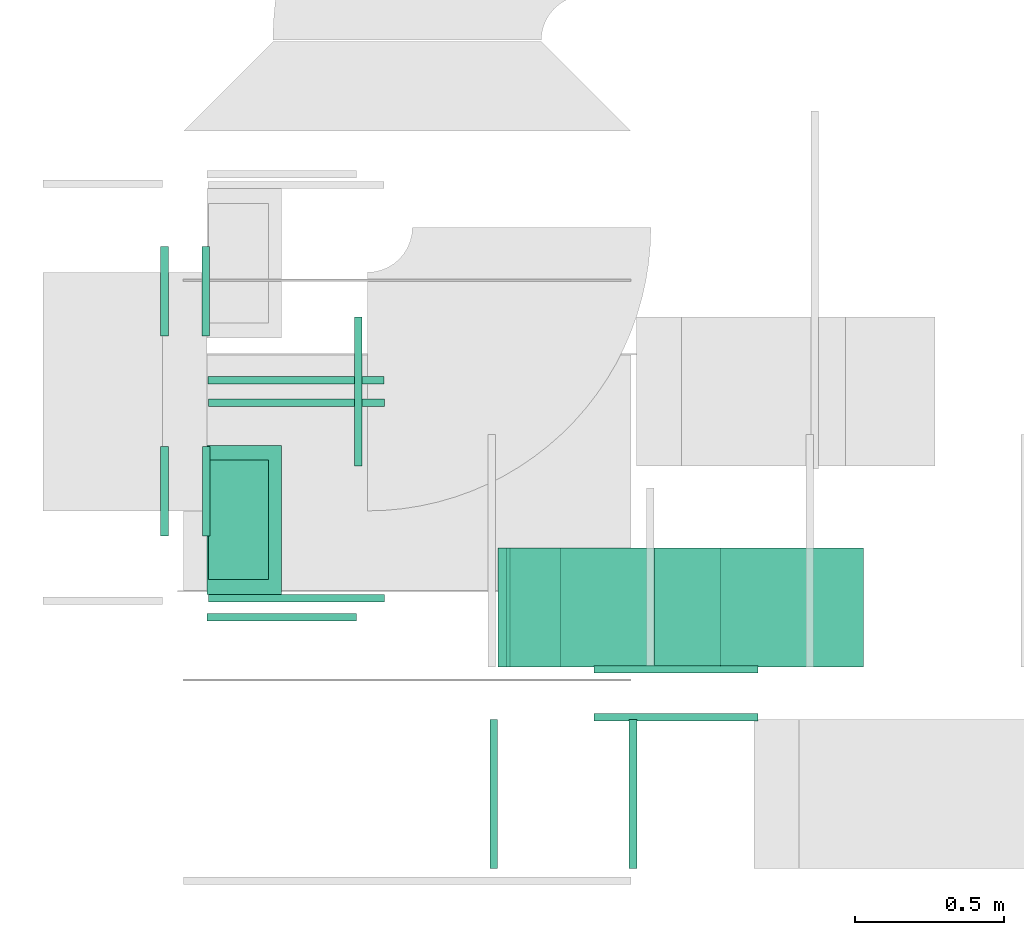
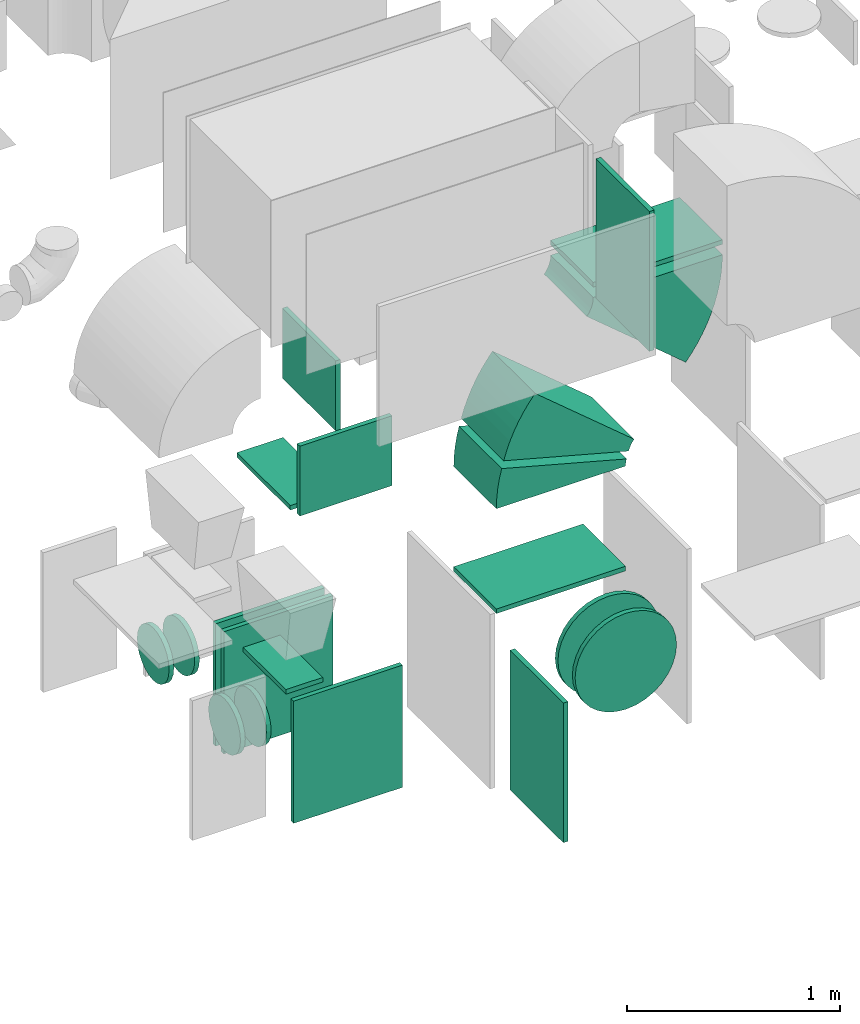
# One storey, part 13 of 59: 20 flow fittings.
"""IFC2X3 building model written with IfcOpenShell, lengths in millimetres."""

from ifc_helpers import new_model, entity, si_unit, converted_unit, derived_unit, direction, frame, frame_2d, origin, origin_2d_with_axis, place, context, subcontext, project, spatial, polyline, circle_curve, parameter, trimmed, segment, composite_curve, rectangle, outline, extrude, faceted_brep, source, transform, mapped, material, type_object, type_shapes, element, save


model = new_model("IFC2X3")

# Units and contexts
model_context = context("Model", 3, precision=0.01, world=origin(), true_north=direction((6.12303176911189e-17, 1.0)))
body_context = subcontext(model_context, "Body", "Model", "MODEL_VIEW")
ifc_project = project(units=[si_unit("LENGTHUNIT", "METRE", prefix="MILLI"), si_unit("AREAUNIT", "SQUARE_METRE"), si_unit("VOLUMEUNIT", "CUBIC_METRE"), converted_unit("PLANEANGLEUNIT", "DEGREE", entity("IfcRatioMeasure", 0.0174532925199433), si_unit("PLANEANGLEUNIT", "RADIAN"), dimensions=[0, 0, 0, 0, 0, 0, 0]), si_unit("MASSUNIT", "GRAM", prefix="KILO"), derived_unit("MASSDENSITYUNIT", [(si_unit("MASSUNIT", "GRAM", prefix="KILO"), 1), (si_unit("LENGTHUNIT", "METRE"), -3)]), derived_unit("MOMENTOFINERTIAUNIT", [(si_unit("LENGTHUNIT", "METRE"), 4)]), si_unit("TIMEUNIT", "SECOND"), si_unit("FREQUENCYUNIT", "HERTZ"), si_unit("THERMODYNAMICTEMPERATUREUNIT", "DEGREE_CELSIUS"), derived_unit("THERMALTRANSMITTANCEUNIT", [(si_unit("MASSUNIT", "GRAM", prefix="KILO"), 1), (si_unit("THERMODYNAMICTEMPERATUREUNIT", "KELVIN"), -1), (si_unit("TIMEUNIT", "SECOND"), -3)]), derived_unit("VOLUMETRICFLOWRATEUNIT", [(si_unit("LENGTHUNIT", "METRE"), 3), (si_unit("TIMEUNIT", "SECOND"), -1)]), derived_unit("MASSFLOWRATEUNIT", [(si_unit("MASSUNIT", "GRAM", prefix="KILO"), 1), (si_unit("TIMEUNIT", "SECOND"), -1)]), derived_unit("ROTATIONALFREQUENCYUNIT", [(si_unit("TIMEUNIT", "SECOND"), -1)]), si_unit("ELECTRICCURRENTUNIT", "AMPERE"), si_unit("ELECTRICVOLTAGEUNIT", "VOLT"), si_unit("POWERUNIT", "WATT"), si_unit("FORCEUNIT", "NEWTON", prefix="KILO"), si_unit("ILLUMINANCEUNIT", "LUX"), si_unit("LUMINOUSFLUXUNIT", "LUMEN"), si_unit("LUMINOUSINTENSITYUNIT", "CANDELA"), derived_unit("USERDEFINED", [(si_unit("MASSUNIT", "GRAM", prefix="KILO"), -1), (si_unit("LENGTHUNIT", "METRE"), -2), (si_unit("TIMEUNIT", "SECOND"), 3), (si_unit("LUMINOUSFLUXUNIT", "LUMEN"), 1)]), derived_unit("LINEARVELOCITYUNIT", [(si_unit("LENGTHUNIT", "METRE"), 1), (si_unit("TIMEUNIT", "SECOND"), -1)]), si_unit("PRESSUREUNIT", "PASCAL"), derived_unit("USERDEFINED", [(si_unit("LENGTHUNIT", "METRE"), -2), (si_unit("MASSUNIT", "GRAM", prefix="KILO"), 1), (si_unit("TIMEUNIT", "SECOND"), -2)]), derived_unit("LINEARFORCEUNIT", [(si_unit("MASSUNIT", "GRAM", prefix="KILO"), 1), (si_unit("LENGTHUNIT", "METRE"), 1), (si_unit("TIMEUNIT", "SECOND"), -2), (si_unit("LENGTHUNIT", "METRE"), -1)]), derived_unit("PLANARFORCEUNIT", [(si_unit("MASSUNIT", "GRAM", prefix="KILO"), 1), (si_unit("LENGTHUNIT", "METRE"), 1), (si_unit("TIMEUNIT", "SECOND"), -2), (si_unit("LENGTHUNIT", "METRE"), -2)])], contexts=[model_context])

# Site, building, storey
site_placement = place(None, origin())
site = spatial("IfcSite", under=ifc_project, at=site_placement, CompositionType="ELEMENT")
building_placement = place(site_placement, origin())
building = spatial("IfcBuilding", under=site, at=building_placement, CompositionType="ELEMENT")
storey_placement = place(building_placement, frame((0.0, 0.0, 28200.0)))
storey = spatial("IfcBuildingStorey", under=building, at=storey_placement, CompositionType="ELEMENT", Elevation=28200.0)

# Flow fittings
ifc_material = material()
duct_fitting_type_1 = type_object("IfcDuctFittingType", PredefinedType="NOTDEFINED", material=ifc_material)
shared_shape_1 = source(origin(), body_context, "Body", "SweptSolid", [
    extrude(rectangle(XDim=26.0960000000006, YDim=400.0, at=origin_2d_with_axis()), frame((6.95, 0.0, -100.0)), (0.0, 0.0, 1.0), 200.0),
])
type_shapes(duct_fitting_type_1, [shared_shape_1])
flow_fitting_1_placement = place(storey_placement, frame((42620.03, 9043.67, 900.0), z_axis=(-1.0, 0.0, 0.0), x_axis=(0.0, 0.0, 1.0)))
element("IfcFlowFitting", 1, at=flow_fitting_1_placement, inside=storey, type_object=duct_fitting_type_1, material=ifc_material, context=body_context, shape_type="MappedRepresentation", body=[
    mapped(shared_shape_1, transform((0.0, 0.0, 0.0), scale=1.0)),
])
duct_fitting_type_2 = type_object("IfcDuctFittingType", PredefinedType="NOTDEFINED", material=ifc_material)
shared_shape_2 = source(origin(), body_context, "Body", "SweptSolid", [
    extrude(rectangle(XDim=500.0, YDim=26.0960000000433, at=origin_2d_with_axis()), frame((6.95, 0.0, -200.0), z_axis=(0.0, 0.0, 1.0), x_axis=(0.0, -1.0, 0.0)), (0.0, 0.0, 1.0), 400.0),
])
type_shapes(duct_fitting_type_2, [shared_shape_2])
flow_fitting_2_placement = place(storey_placement, frame((43015.03, 9473.67, 2200.0), z_axis=(0.0, 0.0, -1.0), x_axis=(1.0, 0.0, 0.0)))
element("IfcFlowFitting", 2, at=flow_fitting_2_placement, inside=storey, type_object=duct_fitting_type_2, material=ifc_material, context=body_context, shape_type="MappedRepresentation", body=[
    mapped(shared_shape_2, transform((0.0, 0.0, 0.0), scale=1.0)),
])
duct_fitting_type_3 = type_object("IfcDuctFittingType", PredefinedType="NOTDEFINED", material=ifc_material)
shared_shape_3 = source(origin(), body_context, "Body", "SweptSolid", [
    extrude(rectangle(XDim=24.9999999999999, YDim=500.0, at=origin_2d_with_axis()), frame((12.5, 0.0, -200.0)), (0.0, 0.0, 1.0), 400.0),
])
type_shapes(duct_fitting_type_3, [shared_shape_3])
flow_fitting_3_placement = place(storey_placement, frame((42765.03, 8729.25, 2200.0), z_axis=(0.0, 0.0, 1.0), x_axis=(0.0, -1.0, 0.0)))
element("IfcFlowFitting", 3, at=flow_fitting_3_placement, inside=storey, type_object=duct_fitting_type_3, material=ifc_material, context=body_context, shape_type="MappedRepresentation", body=[
    mapped(shared_shape_3, transform((0.0, 0.0, 0.0), scale=1.0)),
])
duct_fitting_type_4 = type_object("IfcDuctFittingType", PredefinedType="NOTDEFINED", material=ifc_material)
shared_shape_4 = source(origin(), body_context, "Body", "SweptSolid", [
    extrude(rectangle(XDim=24.9999999999999, YDim=500.0, at=origin_2d_with_axis()), frame((12.5, 0.0, -400.0)), (0.0, 0.0, 1.0), 800.0),
])
type_shapes(duct_fitting_type_4, [shared_shape_4])
flow_fitting_4_placement = place(storey_placement, frame((43488.79, 8124.6, 700.0), z_axis=(0.0, 0.0, 1.0), x_axis=(-1.0, 0.0, 0.0)))
element("IfcFlowFitting", 4, at=flow_fitting_4_placement, inside=storey, type_object=duct_fitting_type_4, material=ifc_material, context=body_context, shape_type="MappedRepresentation", body=[
    mapped(shared_shape_4, transform((0.0, 0.0, 0.0), scale=1.0)),
])
duct_fitting_type_5 = type_object("IfcDuctFittingType", PredefinedType="NOTDEFINED", material=ifc_material)
shared_shape_5 = source(origin(), body_context, "Body", "SweptSolid", [
    extrude(rectangle(XDim=500.0, YDim=26.0960000001386, at=origin_2d_with_axis()), frame((6.95, 0.0, -125.0), z_axis=(0.0, 0.0, 1.0), x_axis=(0.0, -1.0, 0.0)), (0.0, 0.0, 1.0), 250.0),
])
type_shapes(duct_fitting_type_5, [shared_shape_5])
flow_fitting_5_placement = place(storey_placement, frame((42640.03, 9043.67, 2000.0), z_axis=(-1.0, 0.0, 0.0), x_axis=(0.0, 0.0, -1.0)))
element("IfcFlowFitting", 5, at=flow_fitting_5_placement, inside=storey, type_object=duct_fitting_type_5, material=ifc_material, context=body_context, shape_type="MappedRepresentation", body=[
    mapped(shared_shape_5, transform((0.0, 0.0, 0.0), scale=1.0)),
])
duct_fitting_type_6 = type_object("IfcDuctFittingType", PredefinedType="NOTDEFINED", material=ifc_material)
shared_shape_6 = source(origin(), body_context, "Body", "SweptSolid", [
    extrude(rectangle(XDim=500.0, YDim=26.0960000000953, at=origin_2d_with_axis()), frame((6.95, 0.0, -400.0), z_axis=(0.0, 0.0, 1.0), x_axis=(0.0, -1.0, 0.0)), (0.0, 0.0, 1.0), 800.0),
])
type_shapes(duct_fitting_type_6, [shared_shape_6])
flow_fitting_6_placement = place(storey_placement, frame((43935.45, 8124.6, 3351.2), z_axis=(0.0, 0.0, -1.0), x_axis=(1.0, 0.0, 0.0)))
element("IfcFlowFitting", 6, at=flow_fitting_6_placement, inside=storey, type_object=duct_fitting_type_6, material=ifc_material, context=body_context, shape_type="MappedRepresentation", body=[
    mapped(shared_shape_6, transform((0.0, 0.0, 0.0), scale=1.0)),
])
duct_fitting_type_7 = type_object("IfcDuctFittingType", PredefinedType="NOTDEFINED", material=ifc_material)
shared_shape_7 = source(origin(), body_context, "Body", "SweptSolid", [
    extrude(rectangle(XDim=400.0, YDim=26.0960000000087, at=origin_2d_with_axis()), frame((6.95, 0.0, -350.0), z_axis=(0.0, 0.0, 1.0), x_axis=(0.0, -1.0, 0.0)), (0.0, 0.0, 1.0), 700.0),
])
type_shapes(duct_fitting_type_7, [shared_shape_7])
for number, where, z_axis, x_axis in (
    (7, (43840.41, 8749.6, 1200.0), (1.0, 0.0, 0.0), (0.0, 0.0, 1.0)),
    (8, (44365.25, 8749.6, 2900.0), (-1.0, 0.0, 0.0), (0.0, 0.0, -1.0)),
):
    element("IfcFlowFitting", number, at=place(storey_placement, frame(where, z_axis=z_axis, x_axis=x_axis)), inside=storey, type_object=duct_fitting_type_7, material=ifc_material, context=body_context, shape_type="MappedRepresentation", body=[
        mapped(shared_shape_7, transform((0.0, 0.0, 0.0), scale=1.0)),
    ])
duct_fitting_type_8 = type_object("IfcDuctFittingType", PredefinedType="NOTDEFINED", material=ifc_material)
shared_shape_8 = source(origin(), body_context, "Body", "SweptSolid", [
    extrude(rectangle(XDim=24.9999999999999, YDim=590.0, at=origin_2d_with_axis()), frame((12.5, 0.0, -350.0)), (0.0, 0.0, 1.0), 700.0),
])
type_shapes(duct_fitting_type_8, [shared_shape_8])
for number, where, z_axis, x_axis in (
    (9, (42814.03, 8793.67, 550.0), (0.0, 0.0, 1.0), (0.0, -1.0, 0.0)),
    (10, (42814.03, 9423.67, 550.0), (0.0, 0.0, 1.0), (0.0, 1.0, 0.0)),
    (11, (42812.57, 9523.67, 550.0), (0.0, 0.0, 1.0), (0.0, -1.0, 0.0)),
):
    element("IfcFlowFitting", number, at=place(storey_placement, frame(where, z_axis=z_axis, x_axis=x_axis)), inside=storey, type_object=duct_fitting_type_8, material=ifc_material, context=body_context, shape_type="MappedRepresentation", body=[
        mapped(shared_shape_8, transform((0.0, 0.0, 0.0), scale=1.0)),
    ])
duct_fitting_type_9 = type_object("IfcDuctFittingType", PredefinedType="NOTDEFINED", material=ifc_material)
shared_shape_9 = source(origin(), body_context, "Body", "Brep", [
    faceted_brep([(20.0, 0.0, -150.0), (20.0, 38.82, -144.89), (20.0, 75.0, -129.9), (20.0, 106.07, -106.07), (20.0, 129.9, -75.0), (20.0, 144.89, -38.82), (20.0, 150.0, 0.0), (20.0, 144.89, 38.82), (20.0, 129.9, 75.0), (20.0, 106.07, 106.07), (20.0, 75.0, 129.9), (20.0, 38.82, 144.89), (20.0, 0.0, 150.0), (20.0, -38.82, 144.89), (20.0, -75.0, 129.9), (20.0, -106.07, 106.07), (20.0, -129.9, 75.0), (20.0, -144.89, 38.82), (20.0, -150.0, 0.0), (20.0, -144.89, -38.82), (20.0, -129.9, -75.0), (20.0, -106.07, -106.07), (20.0, -75.0, -129.9), (20.0, -38.82, -144.89), (0.0, 0.0, 150.0), (-6.1, 0.0, 150.0), (-6.1, -38.82, 144.89), (0.0, -38.82, 144.89), (-6.1, -75.0, 129.9), (0.0, -75.0, 129.9), (0.0, -106.07, 106.07), (-6.1, -106.07, 106.07), (0.0, -129.9, 75.0), (-6.1, -129.9, 75.0), (-6.1, -144.89, 38.82), (0.0, -144.89, 38.82), (-6.1, -150.0, 0.0), (0.0, -150.0, 0.0), (-6.1, -144.89, -38.82), (0.0, -144.89, -38.82), (-6.1, -129.9, -75.0), (0.0, -129.9, -75.0), (0.0, -106.07, -106.07), (-6.1, -106.07, -106.07), (0.0, -75.0, -129.9), (-6.1, -75.0, -129.9), (-6.1, -38.82, -144.89), (0.0, -38.82, -144.89), (-6.1, 0.0, -150.0), (0.0, 0.0, -150.0), (-6.1, 38.82, -144.89), (0.0, 38.82, -144.89), (-6.1, 75.0, -129.9), (0.0, 75.0, -129.9), (0.0, 106.07, -106.07), (-6.1, 106.07, -106.07), (0.0, 129.9, -75.0), (-6.1, 129.9, -75.0), (-6.1, 144.89, -38.82), (0.0, 144.89, -38.82), (-6.1, 150.0, 0.0), (0.0, 150.0, 0.0), (-6.1, 144.89, 38.82), (0.0, 144.89, 38.82), (-6.1, 129.9, 75.0), (0.0, 129.9, 75.0), (0.0, 106.07, 106.07), (-6.1, 106.07, 106.07), (0.0, 75.0, 129.9), (-6.1, 75.0, 129.9), (-6.1, 38.82, 144.89), (0.0, 38.82, 144.89)], [[[0, 1, 2, 3, 4, 5, 6, 7, 8, 9, 10, 11, 12, 13, 14, 15, 16, 17, 18, 19, 20, 21, 22, 23]], [[13, 12, 24, 25, 26, 27]], [[14, 13, 27, 26, 28, 29]], [[30, 15, 14, 29, 28, 31]], [[17, 16, 32, 33, 34, 35]], [[18, 17, 35, 34, 36, 37]], [[32, 16, 15, 30, 31, 33]], [[19, 18, 37, 36, 38, 39]], [[20, 19, 39, 38, 40, 41]], [[42, 21, 20, 41, 40, 43]], [[23, 22, 44, 45, 46, 47]], [[0, 23, 47, 46, 48, 49]], [[44, 22, 21, 42, 43, 45]], [[1, 0, 49, 48, 50, 51]], [[2, 1, 51, 50, 52, 53]], [[54, 3, 2, 53, 52, 55]], [[5, 4, 56, 57, 58, 59]], [[6, 5, 59, 58, 60, 61]], [[56, 4, 3, 54, 55, 57]], [[7, 6, 61, 60, 62, 63]], [[8, 7, 63, 62, 64, 65]], [[66, 9, 8, 65, 64, 67]], [[11, 10, 68, 69, 70, 71]], [[12, 11, 71, 70, 25, 24]], [[68, 10, 9, 66, 67, 69]], [[46, 45, 43, 40, 38, 36, 34, 33, 31, 28, 26, 25, 70, 69, 67, 64, 62, 60, 58, 57, 55, 52, 50, 48]]]),
])
type_shapes(duct_fitting_type_9, [shared_shape_9])
for number, where, z_axis, x_axis in (
    (12, (42365.03, 9140.16, 594.61), (0.0, 0.0, -1.0), (1.0, 0.0, 0.0)),
    (13, (42365.03, 9810.16, 594.61), (0.0, 0.0, -1.0), (1.0, 0.0, 0.0)),
    (14, (42517.57, 9810.16, 594.61), (0.0, 0.0, -1.0), (-1.0, 0.0, 0.0)),
):
    element("IfcFlowFitting", number, at=place(storey_placement, frame(where, z_axis=z_axis, x_axis=x_axis)), inside=storey, type_object=duct_fitting_type_9, material=ifc_material, context=body_context, shape_type="MappedRepresentation", body=[
        mapped(shared_shape_9, transform((0.0, 0.0, 0.0), scale=1.0)),
    ])
duct_fitting_type_10 = type_object("IfcDuctFittingType", PredefinedType="NOTDEFINED", material=ifc_material)
shared_shape_10 = source(origin(), body_context, "Body", "Brep", [
    faceted_brep([(20.0, 38.82, -144.89), (20.0, 75.0, -129.9), (20.0, 106.07, -106.07), (20.0, 129.9, -75.0), (20.0, 144.89, -38.82), (20.0, 150.0, 0.0), (20.0, 144.89, 38.82), (20.0, 129.9, 75.0), (20.0, 106.07, 106.07), (20.0, 75.0, 129.9), (20.0, 38.82, 144.89), (20.0, 0.0, 150.0), (20.0, -38.82, 144.89), (20.0, -75.0, 129.9), (20.0, -106.07, 106.07), (20.0, -129.9, 75.0), (20.0, -144.89, 38.82), (20.0, -150.0, 0.0), (20.0, -144.89, -38.82), (20.0, -129.9, -75.0), (20.0, -106.07, -106.07), (20.0, -75.0, -129.9), (20.0, -38.82, -144.89), (20.0, 0.0, -150.0), (0.0, 0.0, 150.0), (0.0, 38.82, 144.89), (-6.1, 38.82, 144.89), (-6.1, 0.0, 150.0), (0.0, 75.0, 129.9), (-6.1, 75.0, 129.9), (0.0, 106.07, 106.07), (-6.1, 106.07, 106.07), (0.0, 129.9, 75.0), (0.0, 144.89, 38.82), (-6.1, 144.89, 38.82), (-6.1, 129.9, 75.0), (0.0, 150.0, 0.0), (-6.1, 150.0, 0.0), (0.0, 144.89, -38.82), (-6.1, 144.89, -38.82), (0.0, 129.9, -75.0), (-6.1, 129.9, -75.0), (0.0, 106.07, -106.07), (-6.1, 106.07, -106.07), (0.0, 75.0, -129.9), (0.0, 38.82, -144.89), (-6.1, 38.82, -144.89), (-6.1, 75.0, -129.9), (0.0, 0.0, -150.0), (-6.1, 0.0, -150.0), (0.0, -38.82, -144.89), (-6.1, -38.82, -144.89), (0.0, -75.0, -129.9), (-6.1, -75.0, -129.9), (0.0, -106.07, -106.07), (-6.1, -106.07, -106.07), (0.0, -129.9, -75.0), (0.0, -144.89, -38.82), (-6.1, -144.89, -38.82), (-6.1, -129.9, -75.0), (0.0, -150.0, 0.0), (-6.1, -150.0, 0.0), (0.0, -144.89, 38.82), (-6.1, -144.89, 38.82), (0.0, -129.9, 75.0), (-6.1, -129.9, 75.0), (0.0, -106.07, 106.07), (-6.1, -106.07, 106.07), (0.0, -75.0, 129.9), (0.0, -38.82, 144.89), (-6.1, -38.82, 144.89), (-6.1, -75.0, 129.9)], [[[0, 1, 2, 3, 4, 5, 6, 7, 8, 9, 10, 11, 12, 13, 14, 15, 16, 17, 18, 19, 20, 21, 22, 23]], [[24, 11, 10, 25, 26, 27]], [[25, 10, 9, 28, 29, 26]], [[28, 9, 8, 30, 31, 29]], [[32, 7, 6, 33, 34, 35]], [[33, 6, 5, 36, 37, 34]], [[30, 8, 7, 32, 35, 31]], [[36, 5, 4, 38, 39, 37]], [[38, 4, 3, 40, 41, 39]], [[40, 3, 2, 42, 43, 41]], [[44, 1, 0, 45, 46, 47]], [[45, 0, 23, 48, 49, 46]], [[42, 2, 1, 44, 47, 43]], [[48, 23, 22, 50, 51, 49]], [[50, 22, 21, 52, 53, 51]], [[52, 21, 20, 54, 55, 53]], [[56, 19, 18, 57, 58, 59]], [[57, 18, 17, 60, 61, 58]], [[54, 20, 19, 56, 59, 55]], [[60, 17, 16, 62, 63, 61]], [[62, 16, 15, 64, 65, 63]], [[64, 15, 14, 66, 67, 65]], [[68, 13, 12, 69, 70, 71]], [[69, 12, 11, 24, 27, 70]], [[66, 14, 13, 68, 71, 67]], [[49, 51, 53, 55, 59, 58, 61, 63, 65, 67, 71, 70, 27, 26, 29, 31, 35, 34, 37, 39, 41, 43, 47, 46]]]),
])
type_shapes(duct_fitting_type_10, [shared_shape_10])
flow_fitting_7_placement = place(storey_placement, frame((42519.03, 9140.16, 594.61), z_axis=(0.0, 0.0, -1.0), x_axis=(-1.0, 0.0, 0.0)))
element("IfcFlowFitting", 15, at=flow_fitting_7_placement, inside=storey, type_object=duct_fitting_type_10, material=ifc_material, context=body_context, shape_type="MappedRepresentation", body=[
    mapped(shared_shape_10, transform((0.0, 0.0, 0.0), scale=1.0)),
])
duct_fitting_type_11 = type_object("IfcDuctFittingType", PredefinedType="NOTDEFINED", material=ifc_material)
shared_shape_11 = source(origin(), body_context, "Body", "Brep", [
    faceted_brep([(20.0, -105.24, -254.07), (20.0, -53.65, -269.72), (20.0, 0.0, -275.0), (20.0, 53.65, -269.72), (20.0, 105.24, -254.07), (20.0, 152.78, -228.65), (20.0, 194.45, -194.45), (20.0, 228.65, -152.78), (20.0, 254.07, -105.24), (20.0, 269.72, -53.65), (20.0, 275.0, 0.0), (20.0, 269.72, 53.65), (20.0, 254.07, 105.24), (20.0, 228.65, 152.78), (20.0, 194.45, 194.45), (20.0, 152.78, 228.65), (20.0, 105.24, 254.07), (20.0, 53.65, 269.72), (20.0, 0.0, 275.0), (20.0, -53.65, 269.72), (20.0, -105.24, 254.07), (20.0, -152.78, 228.65), (20.0, -194.45, 194.45), (20.0, -228.65, 152.78), (20.0, -254.07, 105.24), (20.0, -269.72, 53.65), (20.0, -275.0, 0.0), (20.0, -269.72, -53.65), (20.0, -254.07, -105.24), (20.0, -228.65, -152.78), (20.0, -194.45, -194.45), (20.0, -152.78, -228.65), (0.0, 0.0, 275.0), (0.0, -35.96, 271.46), (0.0, -53.65, 269.72), (-6.1, -26.82, 272.36), (-6.1, 0.0, 275.0), (-6.1, -53.65, 269.72), (0.0, -79.44, 261.89), (-6.1, -79.44, 261.89), (0.0, -105.24, 254.07), (-6.1, -105.24, 254.07), (0.0, -129.01, 241.36), (-6.1, -129.01, 241.36), (0.0, -152.78, 228.65), (-6.1, -152.78, 228.65), (0.0, -173.62, 211.55), (0.0, -194.45, 194.45), (-6.1, -173.62, 211.55), (-6.1, -194.45, 194.45), (0.0, -228.65, 152.78), (0.0, -241.36, 129.01), (-6.1, -228.65, 152.78), (-6.1, -241.36, 129.01), (-6.1, -254.07, 105.24), (0.0, -254.07, 105.24), (0.0, -269.72, 53.65), (0.0, -261.89, 79.44), (-6.1, -269.72, 53.65), (-6.1, -261.89, 79.44), (0.0, -275.0, 0.0), (0.0, -271.46, 35.96), (-6.1, -272.36, 26.82), (-6.1, -275.0, 0.0), (0.0, -211.55, 173.62), (-6.1, -211.55, 173.62), (0.0, -271.46, -35.96), (0.0, -269.72, -53.65), (-6.1, -272.36, -26.82), (-6.1, -269.72, -53.65), (0.0, -261.89, -79.44), (-6.1, -261.89, -79.44), (0.0, -254.07, -105.24), (-6.1, -254.07, -105.24), (0.0, -241.36, -129.01), (-6.1, -241.36, -129.01), (0.0, -228.65, -152.78), (-6.1, -228.65, -152.78), (0.0, -211.55, -173.62), (0.0, -194.45, -194.45), (-6.1, -211.55, -173.62), (-6.1, -194.45, -194.45), (0.0, -105.24, -254.07), (0.0, -129.01, -241.36), (0.0, -152.78, -228.65), (-6.1, -129.01, -241.36), (-6.1, -152.78, -228.65), (-6.1, -105.24, -254.07), (0.0, -53.65, -269.72), (0.0, -79.44, -261.89), (-6.1, -79.44, -261.89), (-6.1, -53.65, -269.72), (0.0, 0.0, -275.0), (0.0, -35.96, -271.46), (-6.1, -26.82, -272.36), (-6.1, 0.0, -275.0), (0.0, -173.62, -211.55), (-6.1, -173.62, -211.55), (0.0, 35.96, -271.46), (0.0, 53.65, -269.72), (-6.1, 26.82, -272.36), (-6.1, 53.65, -269.72), (0.0, 79.44, -261.89), (-6.1, 79.44, -261.89), (0.0, 105.24, -254.07), (-6.1, 105.24, -254.07), (0.0, 129.01, -241.36), (-6.1, 129.01, -241.36), (0.0, 152.78, -228.65), (-6.1, 152.78, -228.65), (0.0, 173.62, -211.55), (0.0, 194.45, -194.45), (-6.1, 173.62, -211.55), (-6.1, 194.45, -194.45), (0.0, 254.07, -105.24), (0.0, 241.36, -129.01), (0.0, 228.65, -152.78), (-6.1, 241.36, -129.01), (-6.1, 228.65, -152.78), (-6.1, 254.07, -105.24), (0.0, 269.72, -53.65), (0.0, 261.89, -79.44), (-6.1, 269.72, -53.65), (-6.1, 261.89, -79.44), (0.0, 275.0, 0.0), (0.0, 271.46, -35.96), (-6.1, 272.36, -26.82), (-6.1, 275.0, 0.0), (0.0, 211.55, -173.62), (-6.1, 211.55, -173.62), (0.0, 271.46, 35.96), (0.0, 269.72, 53.65), (-6.1, 272.36, 26.82), (-6.1, 269.72, 53.65), (0.0, 261.89, 79.44), (-6.1, 261.89, 79.44), (0.0, 254.07, 105.24), (-6.1, 254.07, 105.24), (0.0, 241.36, 129.01), (-6.1, 241.36, 129.01), (0.0, 228.65, 152.78), (-6.1, 228.65, 152.78), (0.0, 211.55, 173.62), (0.0, 194.45, 194.45), (-6.1, 211.55, 173.62), (-6.1, 194.45, 194.45), (0.0, 152.78, 228.65), (0.0, 129.01, 241.36), (-6.1, 152.78, 228.65), (-6.1, 129.01, 241.36), (0.0, 105.24, 254.07), (-6.1, 105.24, 254.07), (0.0, 53.65, 269.72), (0.0, 79.44, 261.89), (-6.1, 53.65, 269.72), (-6.1, 79.44, 261.89), (0.0, 35.96, 271.46), (-6.1, 26.82, 272.36), (0.0, 173.62, 211.55), (-6.1, 173.62, 211.55)], [[[0, 1, 2, 3, 4, 5, 6, 7, 8, 9, 10, 11, 12, 13, 14, 15, 16, 17, 18, 19, 20, 21, 22, 23, 24, 25, 26, 27, 28, 29, 30, 31]], [[19, 18, 32]], [[19, 32, 33]], [[19, 33, 34]], [[35, 33, 32]], [[35, 32, 36]], [[35, 37, 33]], [[33, 37, 34]], [[34, 20, 19]], [[20, 34, 38]], [[34, 37, 38]], [[39, 38, 37]], [[40, 38, 39]], [[39, 41, 40]], [[20, 38, 40]], [[20, 40, 21]], [[21, 40, 42]], [[41, 42, 40]], [[43, 42, 41]], [[43, 44, 42]], [[43, 45, 44]], [[21, 42, 44]], [[22, 44, 46]], [[22, 21, 44]], [[22, 46, 47]], [[46, 44, 45]], [[46, 45, 48]], [[47, 48, 49]], [[46, 48, 47]], [[50, 24, 23]], [[24, 50, 51]], [[51, 50, 52]], [[53, 51, 52]], [[51, 53, 54]], [[54, 55, 51]], [[24, 51, 55]], [[56, 25, 24]], [[24, 57, 56]], [[58, 56, 57]], [[24, 55, 57]], [[57, 55, 59]], [[54, 59, 55]], [[59, 58, 57]], [[26, 25, 60]], [[25, 61, 60]], [[25, 56, 61]], [[56, 58, 61]], [[62, 61, 58]], [[62, 63, 60]], [[61, 62, 60]], [[23, 47, 64]], [[22, 47, 23]], [[23, 64, 50]], [[64, 47, 49]], [[49, 65, 64]], [[65, 52, 50]], [[64, 65, 50]], [[27, 26, 60]], [[27, 60, 66]], [[27, 66, 67]], [[68, 66, 60]], [[68, 60, 63]], [[68, 69, 66]], [[66, 69, 67]], [[67, 28, 27]], [[28, 67, 70]], [[67, 69, 70]], [[71, 70, 69]], [[72, 70, 71]], [[71, 73, 72]], [[28, 70, 72]], [[28, 72, 29]], [[29, 72, 74]], [[73, 74, 72]], [[75, 74, 73]], [[75, 76, 74]], [[75, 77, 76]], [[29, 74, 76]], [[30, 76, 78]], [[30, 29, 76]], [[30, 78, 79]], [[78, 76, 77]], [[78, 77, 80]], [[79, 80, 81]], [[78, 80, 79]], [[0, 31, 82]], [[31, 83, 82]], [[31, 84, 83]], [[83, 84, 85]], [[86, 85, 84]], [[85, 87, 83]], [[87, 82, 83]], [[1, 0, 88]], [[0, 89, 88]], [[0, 82, 89]], [[89, 82, 90]], [[87, 90, 82]], [[90, 91, 89]], [[91, 88, 89]], [[2, 1, 92]], [[1, 93, 92]], [[1, 88, 93]], [[88, 91, 93]], [[94, 93, 91]], [[94, 95, 92]], [[93, 94, 92]], [[31, 79, 96]], [[30, 79, 31]], [[31, 96, 84]], [[96, 79, 81]], [[81, 97, 96]], [[97, 86, 96]], [[96, 86, 84]], [[3, 2, 92]], [[3, 92, 98]], [[3, 98, 99]], [[100, 98, 92]], [[100, 92, 95]], [[100, 101, 98]], [[98, 101, 99]], [[99, 4, 3]], [[4, 99, 102]], [[99, 101, 102]], [[103, 102, 101]], [[104, 102, 103]], [[103, 105, 104]], [[4, 102, 104]], [[4, 104, 5]], [[5, 104, 106]], [[105, 106, 104]], [[107, 106, 105]], [[107, 108, 106]], [[107, 109, 108]], [[5, 106, 108]], [[6, 108, 110]], [[6, 5, 108]], [[6, 110, 111]], [[110, 108, 109]], [[110, 109, 112]], [[110, 112, 111]], [[111, 112, 113]], [[8, 7, 114]], [[7, 115, 114]], [[7, 116, 115]], [[115, 116, 117]], [[118, 117, 116]], [[117, 119, 115]], [[119, 114, 115]], [[120, 9, 8]], [[8, 121, 120]], [[122, 120, 121]], [[8, 114, 121]], [[121, 114, 123]], [[119, 123, 114]], [[123, 122, 121]], [[9, 124, 10]], [[9, 125, 124]], [[9, 120, 125]], [[120, 122, 125]], [[126, 125, 122]], [[126, 127, 124]], [[125, 126, 124]], [[6, 111, 128]], [[6, 128, 116]], [[7, 6, 116]], [[111, 113, 128]], [[129, 128, 113]], [[129, 118, 128]], [[128, 118, 116]], [[11, 10, 124]], [[11, 124, 130]], [[11, 130, 131]], [[132, 130, 124]], [[132, 124, 127]], [[132, 133, 130]], [[130, 133, 131]], [[131, 12, 11]], [[12, 131, 134]], [[131, 133, 134]], [[135, 134, 133]], [[136, 134, 135]], [[135, 137, 136]], [[12, 134, 136]], [[12, 136, 13]], [[13, 136, 138]], [[137, 138, 136]], [[139, 138, 137]], [[139, 140, 138]], [[139, 141, 140]], [[13, 138, 140]], [[14, 140, 142]], [[14, 13, 140]], [[14, 142, 143]], [[142, 140, 141]], [[142, 141, 144]], [[143, 144, 145]], [[142, 144, 143]], [[146, 16, 15]], [[16, 146, 147]], [[148, 147, 146]], [[149, 147, 148]], [[147, 149, 150]], [[149, 151, 150]], [[16, 147, 150]], [[152, 17, 16]], [[16, 153, 152]], [[154, 152, 153]], [[16, 150, 153]], [[153, 150, 155]], [[151, 155, 150]], [[155, 154, 153]], [[18, 17, 32]], [[17, 156, 32]], [[17, 152, 156]], [[152, 154, 156]], [[157, 156, 154]], [[157, 36, 32]], [[156, 157, 32]], [[14, 143, 158]], [[14, 158, 146]], [[15, 14, 146]], [[158, 143, 145]], [[145, 159, 158]], [[159, 148, 146]], [[158, 159, 146]], [[37, 35, 36, 157, 154, 155, 151, 149, 148, 159, 145, 144, 141, 139, 137, 135, 133, 132, 127, 126, 122, 123, 119, 117, 118, 129, 113, 112, 109, 107, 105, 103, 101, 100, 95, 94, 91, 90, 87, 85, 86, 97, 81, 80, 77, 75, 73, 71, 69, 68, 63, 62, 58, 59, 54, 53, 52, 65, 49, 48, 45, 43, 41, 39]]]),
])
type_shapes(duct_fitting_type_11, [shared_shape_11])
for number, where, z_axis, x_axis in (
    (16, (44087.33, 8374.6, 821.95), (0.0, 0.0, -1.0), (0.0, 1.0, 0.0)),
    (17, (44087.33, 8549.6, 821.95), (0.0, 0.0, -1.0), (0.0, -1.0, 0.0)),
):
    element("IfcFlowFitting", number, at=place(storey_placement, frame(where, z_axis=z_axis, x_axis=x_axis)), inside=storey, type_object=duct_fitting_type_11, material=ifc_material, context=body_context, shape_type="MappedRepresentation", body=[
        mapped(shared_shape_11, transform((0.0, 0.0, 0.0), scale=1.0)),
    ])
duct_fitting_type_12 = type_object("IfcDuctFittingType", PredefinedType="NOTDEFINED", material=ifc_material)
shared_shape_12 = source(origin(), body_context, "Body", "SweptSolid", [
    extrude(outline(composite_curve([segment(polyline([(-358.52, -64.7), (341.48, -64.7)]), True, "CONTINUOUS"), segment(trimmed(circle_curve(frame_2d((491.48, -64.7), x_axis=(-0.965925826289068, 0.25881904510252)), 150.0), [parameter(0.0)], [parameter(14.9999999999999)], True, "PARAMETER"), False, "CONTINUOUS"), segment(polyline([(346.59, -25.88), (-329.56, 155.29)]), True, "CONTINUOUS"), segment(trimmed(circle_curve(frame_2d((491.48, -64.7), x_axis=(-0.965925826289068, 0.25881904510252)), 850.0), [parameter(0.0)], [parameter(14.9999999999999)], True, "PARAMETER"), True, "CONTINUOUS")], self_intersect=False)), frame((-1.12, 8.52, -200.0), z_axis=(0.0, 0.0, 1.0), x_axis=(-0.258819045102519, 0.965925826289069, 0.0)), (0.0, 0.0, 1.0), 400.0),
])
type_shapes(duct_fitting_type_12, [shared_shape_12])
flow_fitting_8_placement = place(storey_placement, frame((43840.41, 8749.6, 1860.0), z_axis=(0.0, 1.0, 0.0), x_axis=(0.0, 0.0, 1.0)))
element("IfcFlowFitting", 18, at=flow_fitting_8_placement, inside=storey, type_object=duct_fitting_type_12, material=ifc_material, context=body_context, shape_type="MappedRepresentation", body=[
    mapped(shared_shape_12, transform((0.0, 0.0, 0.0), scale=1.0)),
])
duct_fitting_type_13 = type_object("IfcDuctFittingType", PredefinedType="NOTDEFINED", material=ifc_material)
shared_shape_13 = source(origin(), body_context, "Body", "SweptSolid", [
    extrude(outline(composite_curve([segment(polyline([(-373.42, -105.65), (326.58, -105.65)]), True, "CONTINUOUS"), segment(trimmed(circle_curve(frame_2d((476.58, -105.65), x_axis=(-0.906307787036667, 0.422618261740659)), 150.0), [parameter(0.0)], [parameter(24.9999999999975)], True, "PARAMETER"), False, "CONTINUOUS"), segment(polyline([(340.63, -42.26), (-293.78, 253.57)]), True, "CONTINUOUS"), segment(trimmed(circle_curve(frame_2d((476.58, -105.65), x_axis=(-0.906307787036667, 0.422618261740659)), 850.0), [parameter(0.0)], [parameter(24.9999999999975)], True, "PARAMETER"), True, "CONTINUOUS")], self_intersect=False)), frame((-5.19, 23.42, -200.0), z_axis=(0.0, 0.0, 1.0), x_axis=(-0.422618261740659, 0.906307787036669, 0.0)), (0.0, 0.0, 1.0), 400.0),
])
type_shapes(duct_fitting_type_13, [shared_shape_13])
flow_fitting_9_placement = place(storey_placement, frame((43897.11, 8749.6, 2071.61), z_axis=(0.0, 1.0, 0.0), x_axis=(0.258819045102566, 0.0, 0.965925826289056)))
element("IfcFlowFitting", 19, at=flow_fitting_9_placement, inside=storey, type_object=duct_fitting_type_13, material=ifc_material, context=body_context, shape_type="MappedRepresentation", body=[
    mapped(shared_shape_13, transform((0.0, 0.0, 0.0), scale=1.0)),
])
duct_fitting_type_14 = type_object("IfcDuctFittingType", PredefinedType="NOTDEFINED", material=ifc_material)
shared_shape_14 = source(origin(), body_context, "Body", "SweptSolid", [
    extrude(outline(composite_curve([segment(polyline([(-408.49, -160.7), (291.51, -160.7)]), True, "CONTINUOUS"), segment(trimmed(circle_curve(frame_2d((441.51, -160.7), x_axis=(-0.766044443118943, 0.642787609686579)), 150.0), [parameter(0.0)], [parameter(40.000000000003)], True, "PARAMETER"), False, "CONTINUOUS"), segment(polyline([(326.6, -64.28), (-209.63, 385.67)]), True, "CONTINUOUS"), segment(trimmed(circle_curve(frame_2d((441.51, -160.7), x_axis=(-0.766044443118943, 0.642787609686579)), 850.0), [parameter(0.0)], [parameter(40.000000000003)], True, "PARAMETER"), True, "CONTINUOUS")], self_intersect=False)), frame((-21.29, 58.49, -200.0), z_axis=(0.0, 0.0, 1.0), x_axis=(-0.642787609686579, 0.766044443118945, 0.0)), (0.0, 0.0, 1.0), 400.0),
])
type_shapes(duct_fitting_type_14, [shared_shape_14])
flow_fitting_10_placement = place(storey_placement, frame((44365.25, 8749.6, 2638.35), z_axis=(0.0, -1.0, 0.0), x_axis=(0.642787609686603, 0.0, 0.766044443118924)))
element("IfcFlowFitting", 20, at=flow_fitting_10_placement, inside=storey, type_object=duct_fitting_type_14, material=ifc_material, context=body_context, shape_type="MappedRepresentation", body=[
    mapped(shared_shape_14, transform((0.0, 0.0, 0.0), scale=1.0)),
])

save(model, "model.ifc")
